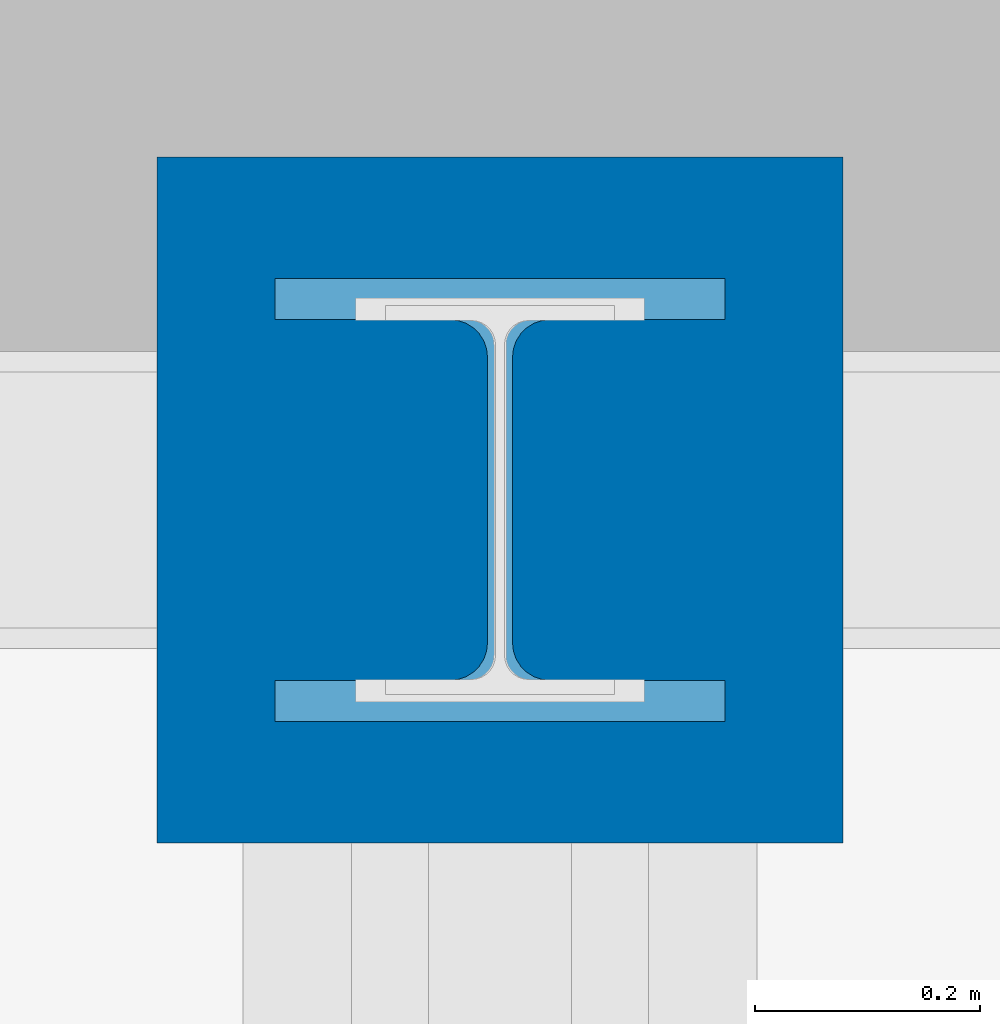
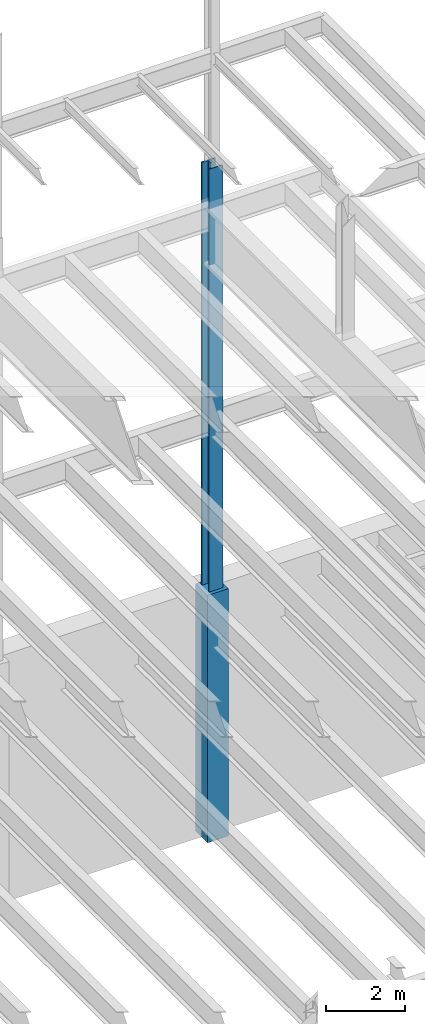
# One storey, part 67 of 150: 2 columns.
"""IFC2X3 building model written with IfcOpenShell, lengths in millimetres."""

from ifc_helpers import new_model, si_unit, frame, origin_with_axes, origin_2d_with_axis, place, context, subcontext, project, spatial, rectangle, i_section, extrude, material, type_object, element, save


model = new_model("IFC2X3")

# Units and contexts
model_context = context("Model", 3, precision=1e-05, world=origin_with_axes())
body_context = subcontext(model_context, "Body", "Model", "MODEL_VIEW")
ifc_project = project(units=[si_unit("LENGTHUNIT", "METRE", prefix="MILLI"), si_unit("AREAUNIT", "SQUARE_METRE"), si_unit("VOLUMEUNIT", "CUBIC_METRE"), si_unit("MASSUNIT", "GRAM", prefix="KILO"), si_unit("TIMEUNIT", "SECOND"), si_unit("PLANEANGLEUNIT", "RADIAN"), si_unit("SOLIDANGLEUNIT", "STERADIAN"), si_unit("THERMODYNAMICTEMPERATUREUNIT", "DEGREE_CELSIUS"), si_unit("LUMINOUSINTENSITYUNIT", "LUMEN")], contexts=[model_context])

# Site, building, storey
site_placement = place(None, origin_with_axes())
site = spatial("IfcSite", under=ifc_project, at=site_placement, CompositionType="ELEMENT")
building_placement = place(site_placement, origin_with_axes())
building = spatial("IfcBuilding", under=site, at=building_placement, Name="Undefined", CompositionType="ELEMENT")
storey_placement = place(building_placement, origin_with_axes())
storey = spatial("IfcBuildingStorey", under=building, at=storey_placement, Name="Undefined", CompositionType="ELEMENT", Elevation=0.0)

# Columns
ifc_material_1 = material(Name="STEEL/A992")
column_type_1 = type_object("IfcColumnType", Name="W14X193", PredefinedType="NOTDEFINED")
column_1_placement = place(storey_placement, frame((43789.6, 38862.0, 22707.6), z_axis=(0.0, 0.0, 1.0), x_axis=(1.0, 0.0, 0.0)))
element("IfcColumn", 1, at=column_1_placement, inside=storey, type_object=column_type_1, material=ifc_material_1, Name="COLUMN", ObjectType="W14X193", context=body_context, shape_type="SweptSolid", body=[
    extrude(i_section(OverallWidth=400.05, OverallDepth=393.7, WebThickness=22.225, FlangeThickness=36.576, FilletRadius=33.2739, at=origin_2d_with_axis()), frame((0.0, 0.0, 14097.0012877801), z_axis=(0.0, 0.0, -1.0), x_axis=(-1.0, 0.0, 0.0)), (0.0, 0.0, 1.0), 14097.0012877801),
])
ifc_material_2 = material(Name="CONCRETE/5000")
column_type_2 = type_object("IfcColumnType", PredefinedType="NOTDEFINED")
column_2_placement = place(storey_placement, frame((43789.6, 38862.0, 16154.4), z_axis=(0.0, 0.0, 1.0), x_axis=(1.0, 0.0, 0.0)))
element("IfcColumn", 2, at=column_2_placement, inside=storey, type_object=column_type_2, material=ifc_material_2, Name="COLUMN", context=body_context, shape_type="SweptSolid", body=[
    extrude(rectangle(XDim=609.6, YDim=609.6, at=origin_2d_with_axis()), frame((0.0, 0.0, 7620.0), z_axis=(0.0, 0.0, -1.0), x_axis=(0.0, -1.0, 0.0)), (0.0, 0.0, 1.0), 7620.0),
])

save(model, "model.ifc")
